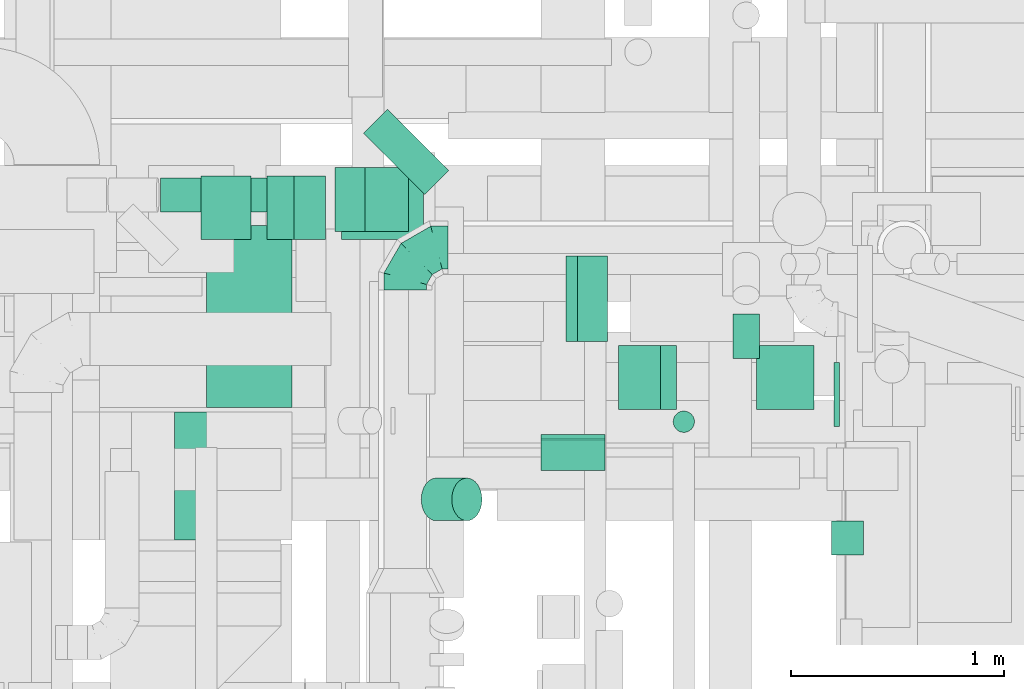
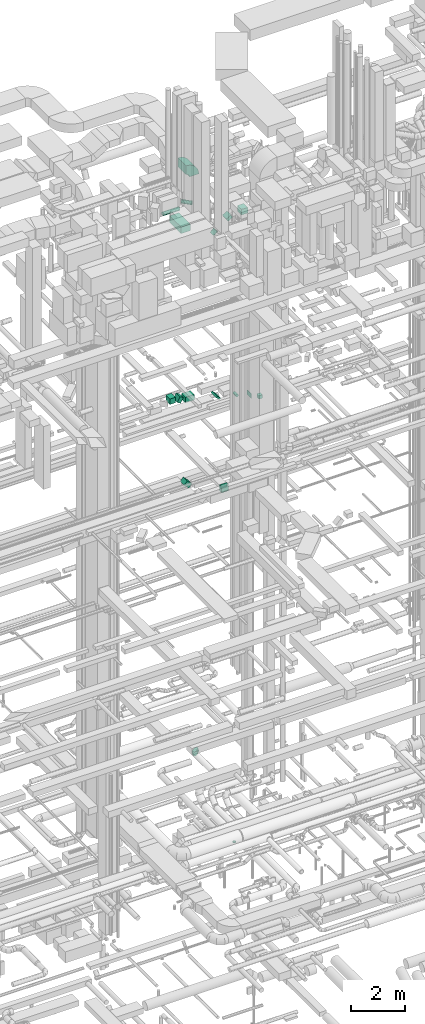
# One storey, part 202 of 337: 16 flow segments, 5 flow fittings.
"""IFC2X3 building model written with IfcOpenShell, lengths in millimetres."""

import ifcopenshell
import ifcopenshell.guid

model = None  # the IFC model being written
_history = None  # IfcOwnerHistory: only IFC2X3 demands one
_inside = {}  # id of a spatial element -> (the spatial element, [elements in it])
_under = {}  # id of a project, library or spatial element -> (it, [spatial elements below it])
_declared = {}  # id of a project -> (the project, [libraries it declares])
_typed = {}  # id of a type object -> (the type object, [elements of that type])
_made_of = {}  # id of a material, layer set ... -> (it, [elements and type objects made of it])


def new_model(schema):
    """Start an empty IFC model of exactly this schema.

    Asked for "IFC4X3", IfcOpenShell would pick the latest addendum, in which some entities
    have other attributes; the version numbers below select the first issue.
    IFC2X3 requires an IfcOwnerHistory on every rooted entity: one is made here for all.
    """
    global model, _history
    if schema == "IFC4X3":
        model = ifcopenshell.file(schema_version=(4, 3, 0, 0))
    else:
        model = ifcopenshell.file(schema=schema)
    _inside.clear()
    _under.clear()
    _declared.clear()
    _typed.clear()
    _made_of.clear()
    _history = None
    if model.schema == "IFC2X3":
        org = make("IfcOrganization", Name="unknown")
        user = make(
            "IfcPersonAndOrganization",
            ThePerson=make("IfcPerson", FamilyName="unknown"),
            TheOrganization=org,
        )
        app = make(
            "IfcApplication",
            ApplicationDeveloper=org,
            Version="unknown",
            ApplicationFullName="unknown",
            ApplicationIdentifier="unknown",
        )
        _history = make(
            "IfcOwnerHistory",
            OwningUser=user,
            OwningApplication=app,
            ChangeAction="ADDED",
            CreationDate=0,
        )
    return model


def make(cls, **values):
    """One entity of the class cls with the attributes given. An attribute that is None is left unset."""
    return model.create_entity(
        cls, **{name: value for name, value in values.items() if value is not None}
    )


def entity(cls, *values):
    """Any entity or typed value of the class cls, its attributes in the order of the schema. None: left unset."""
    e = model.create_entity(cls)
    for i, value in enumerate(values):
        if value is not None:
            e[i] = value
    return e


def rooted(cls, **values):
    """An entity with a GlobalId (a new one), such as an element, a storey or a relation."""
    return make(cls, GlobalId=ifcopenshell.guid.new(), OwnerHistory=_history, **values)


def si_unit(unit_type, name, prefix=None):
    """IfcSIUnit, for example si_unit("LENGTHUNIT", "METRE", prefix="MILLI")."""
    return make("IfcSIUnit", UnitType=unit_type, Prefix=prefix, Name=name)


def converted_unit(unit_type, name, factor, base, dimensions=None, offset=None):
    """IfcConversionBasedUnit, such as the inch: factor (a typed value) times the base unit."""
    return make(
        "IfcConversionBasedUnit"
        if offset is None
        else "IfcConversionBasedUnitWithOffset",
        ConversionOffset=offset,
        Dimensions=None
        if dimensions is None
        else entity("IfcDimensionalExponents", *dimensions),
        UnitType=unit_type,
        Name=name,
        ConversionFactor=make(
            "IfcMeasureWithUnit", ValueComponent=factor, UnitComponent=base
        ),
    )


def derived_unit(unit_type, elements):
    """IfcDerivedUnit: a product of units, each with its exponent."""
    return make(
        "IfcDerivedUnit",
        Elements=[
            make("IfcDerivedUnitElement", Unit=unit, Exponent=power)
            for unit, power in elements
        ],
        UnitType=unit_type,
    )


def assignment(units):
    """IfcUnitAssignment: the units of a project."""
    return None if units is None else make("IfcUnitAssignment", Units=units)


def point(xyz):
    """IfcCartesianPoint."""
    return None if xyz is None else make("IfcCartesianPoint", Coordinates=xyz)


def direction(xyz):
    """IfcDirection."""
    return None if xyz is None else make("IfcDirection", DirectionRatios=xyz)


def frame(location, z_axis=None, x_axis=None):
    """IfcAxis2Placement3D, a coordinate frame: its origin and axes. An axis left out is left unset."""
    return make(
        "IfcAxis2Placement3D",
        Location=point(location),
        Axis=direction(z_axis),
        RefDirection=direction(x_axis),
    )


def frame_2d(location, x_axis=None):
    """IfcAxis2Placement2D, a coordinate frame in the plane: its origin and x axis."""
    return make(
        "IfcAxis2Placement2D", Location=point(location), RefDirection=direction(x_axis)
    )


def origin():
    """The frame at (0, 0, 0) with its axes left unset."""
    return frame((0.0, 0.0, 0.0))


def origin_2d_with_axis():
    """The frame at (0, 0) in the plane with the x axis (1, 0) written out."""
    return frame_2d((0.0, 0.0), x_axis=(1.0, 0.0))


def place(relative_to, where):
    """IfcLocalPlacement: puts the frame where relative to a parent placement (None: the world)."""
    return make(
        "IfcLocalPlacement", PlacementRelTo=relative_to, RelativePlacement=where
    )


def context(
    kind, dimensions, precision=None, world=None, true_north=None, identifier=None
):
    """IfcGeometricRepresentationContext, for example the 3D "Model" context."""
    return make(
        "IfcGeometricRepresentationContext",
        ContextIdentifier=identifier,
        ContextType=kind,
        CoordinateSpaceDimension=dimensions,
        Precision=precision,
        WorldCoordinateSystem=world,
        TrueNorth=true_north,
    )


def subcontext(parent, identifier, kind, view, scale=None):
    """IfcGeometricRepresentationSubContext, for example "Body" below "Model"."""
    return make(
        "IfcGeometricRepresentationSubContext",
        ContextIdentifier=identifier,
        ContextType=kind,
        ParentContext=parent,
        TargetScale=scale,
        TargetView=view,
    )


def project(units=None, contexts=None):
    """IfcProject with its units and contexts."""
    return rooted(
        "IfcProject",
        Name="project",
        RepresentationContexts=contexts,
        UnitsInContext=assignment(units),
    )


def spatial(cls, under=None, at=None, **own):
    """A site, building, storey or space (cls), placed at a placement, below another one or the project."""
    s = rooted(cls, ObjectPlacement=at, **own)
    if under is not None:
        _under.setdefault(under.id(), (under, []))[1].append(s)
    return s


def polyline(points):
    """IfcPolyline through the points."""
    return make("IfcPolyline", Points=[point(p) for p in points])


def circle_curve(where, radius):
    """IfcCircle in the frame where."""
    return make("IfcCircle", Position=where, Radius=radius)


def parameter(value):
    """IfcParameterValue: where a trimmed curve begins or ends, as a parameter of its basis curve."""
    return model.create_entity("IfcParameterValue", value)


def trimmed(basis, trim1, trim2, sense, master):
    """IfcTrimmedCurve: the piece of a basis curve between two trims."""
    return make(
        "IfcTrimmedCurve",
        BasisCurve=basis,
        Trim1=trim1,
        Trim2=trim2,
        SenseAgreement=sense,
        MasterRepresentation=master,
    )


def segment(curve, same_sense, transition):
    """IfcCompositeCurveSegment."""
    return make(
        "IfcCompositeCurveSegment",
        Transition=transition,
        SameSense=same_sense,
        ParentCurve=curve,
    )


def composite_curve(segments, self_intersect=None):
    """IfcCompositeCurve: segments joined end to end."""
    return make("IfcCompositeCurve", Segments=segments, SelfIntersect=self_intersect)


def profile(cls, at=None, kind="AREA", **sizes):
    """A parametric profile (cls). Its sizes go by their IFC names, for example OverallWidth=200.0."""
    return make(cls, ProfileType=kind, Position=at, **sizes)


def rectangle(**sizes):
    """IfcRectangleProfileDef."""
    return profile("IfcRectangleProfileDef", **sizes)


def circle(**sizes):
    """IfcCircleProfileDef."""
    return profile("IfcCircleProfileDef", **sizes)


def outline(outer, holes=None, kind="AREA"):
    """IfcArbitraryClosedProfileDef: a profile drawn as a closed curve; with holes, ...WithVoids."""
    if holes is None:
        return make("IfcArbitraryClosedProfileDef", ProfileType=kind, OuterCurve=outer)
    return make(
        "IfcArbitraryProfileDefWithVoids",
        ProfileType=kind,
        OuterCurve=outer,
        InnerCurves=holes,
    )


def extrude(swept, where, along, depth):
    """IfcExtrudedAreaSolid: the profile swept, set in the frame where, extruded along a direction by depth."""
    return make(
        "IfcExtrudedAreaSolid",
        SweptArea=swept,
        Position=where,
        ExtrudedDirection=direction(along),
        Depth=depth,
    )


def faces_of(points, faces, orient=None, outer=None):
    """IfcFace entities. A face is a list of loops; a loop is a list of indices into points, from 0.

    orient and outer hold one flag for each loop. By default every Orientation is true, the
    first loop of a face is its IfcFaceOuterBound and the others are IfcFaceBound.
    """
    made = []
    for i, loops in enumerate(faces):
        bounds = []
        for j, loop in enumerate(loops):
            is_outer = j == 0 if outer is None else outer[i][j]
            bounds.append(
                make(
                    "IfcFaceOuterBound" if is_outer else "IfcFaceBound",
                    Bound=make("IfcPolyLoop", Polygon=[points[k] for k in loop]),
                    Orientation=True if orient is None else orient[i][j],
                )
            )
        made.append(make("IfcFace", Bounds=bounds))
    return made


def faceted_brep(points, faces, orient=None, outer=None, voids=None):
    """IfcFacetedBrep: a solid bounded by flat faces; with voids (closed shells), ...WithVoids."""
    shared = [point(p) for p in points]
    hull = make("IfcClosedShell", CfsFaces=faces_of(shared, faces, orient, outer))
    if voids is None:
        return make("IfcFacetedBrep", Outer=hull)
    return make(
        "IfcFacetedBrepWithVoids",
        Outer=hull,
        Voids=[
            make(cls, CfsFaces=faces_of(shared, fs, o, b)) for cls, fs, o, b in voids
        ],
    )


def shape(context_of_items, identifier, shape_type, items):
    """IfcShapeRepresentation: the items that make up one representation, for example the "Body"."""
    return make(
        "IfcShapeRepresentation",
        ContextOfItems=context_of_items,
        RepresentationIdentifier=identifier,
        RepresentationType=shape_type,
        Items=items,
    )


def source(mapping_origin, context_of_items, identifier, shape_type, items):
    """IfcRepresentationMap: a shape defined once, which mapped items show again and again."""
    return make(
        "IfcRepresentationMap",
        MappingOrigin=mapping_origin,
        MappedRepresentation=shape(context_of_items, identifier, shape_type, items),
    )


def transform(
    local_origin,
    x_axis=None,
    y_axis=None,
    z_axis=None,
    scale=None,
    scale2=None,
    scale3=None,
    uniform=True,
):
    """IfcCartesianTransformationOperator3D, or its non-uniform kind. x_axis, y_axis, z_axis: its Axis1, 2, 3."""
    if uniform:
        return make(
            "IfcCartesianTransformationOperator3D",
            Axis1=direction(x_axis),
            Axis2=direction(y_axis),
            LocalOrigin=point(local_origin),
            Scale=scale,
            Axis3=direction(z_axis),
        )
    return make(
        "IfcCartesianTransformationOperator3DnonUniform",
        Axis1=direction(x_axis),
        Axis2=direction(y_axis),
        LocalOrigin=point(local_origin),
        Scale=scale,
        Axis3=direction(z_axis),
        Scale2=scale2,
        Scale3=scale3,
    )


def mapped(mapping_source, mapping_target):
    """IfcMappedItem: shows the shape of a source again, moved by a transform."""
    return make(
        "IfcMappedItem", MappingSource=mapping_source, MappingTarget=mapping_target
    )


def material(Name=None, Category=None):
    """IfcMaterial."""
    return make("IfcMaterial", Name=Name, Category=Category)


def made_of(thing, what):
    """Note that an element or type object is made of a material, layer set ...; save() writes the relation."""
    if what is not None:
        _made_of.setdefault(what.id(), (what, []))[1].append(thing)
    return thing


def type_object(cls, material=None, **own):
    """A type object (cls), such as IfcWallType, which elements share."""
    return made_of(rooted(cls, **own), material)


def type_shapes(of_type, sources):
    """Give a type object the sources (RepresentationMaps) that its elements show as mapped items."""
    of_type.RepresentationMaps = sources


def element(
    cls,
    number,
    at=None,
    inside=None,
    cuts=None,
    type_object=None,
    material=None,
    context=None,
    identifier="Body",
    shape_type=None,
    held_by="IfcProductDefinitionShape",
    body=None,
    shapes=None,
    **own,
):
    """One element of the class cls, such as IfcWall. Its Tag is "e" and its number.

    at: its placement. inside: the storey or other place that contains it. cuts: it is an
    opening in that element (IfcRelVoidsElement). A single representation is given by context,
    identifier, shape_type and body (its items); several are given by shapes. held_by: the class
    of the entity that holds the representations. save() writes the other relations.
    """
    e = rooted(cls, Tag="e%d" % number, ObjectPlacement=at, **own)
    if body is not None:
        shapes = [shape(context, identifier, shape_type, body)]
    if shapes is not None:
        e.Representation = make(held_by, Representations=shapes)
    if inside is not None:
        _inside.setdefault(inside.id(), (inside, []))[1].append(e)
    if cuts is not None:
        rooted(
            "IfcRelVoidsElement", RelatingBuildingElement=cuts, RelatedOpeningElement=e
        )
    if type_object is not None:
        _typed.setdefault(type_object.id(), (type_object, []))[1].append(e)
    return made_of(e, material)


def aggregate(whole, parts):
    """IfcRelAggregates: a whole, such as a stair, and the parts it consists of."""
    return rooted("IfcRelAggregates", RelatingObject=whole, RelatedObjects=parts)


def save(model, path):
    """Write the relations noted so far, then the file.

    IfcRelAggregates (storeys below a building ...), IfcRelContainedInSpatialStructure (elements
    in a storey), IfcRelDefinesByType, IfcRelAssociatesMaterial and IfcRelDeclares: one each for
    every whole, place, type object, material and project.
    """
    for whole, parts in _under.values():
        aggregate(whole, parts)
    for where, things in _inside.values():
        rooted(
            "IfcRelContainedInSpatialStructure",
            RelatedElements=things,
            RelatingStructure=where,
        )
    for kind, things in _typed.values():
        rooted("IfcRelDefinesByType", RelatedObjects=things, RelatingType=kind)
    for what, things in _made_of.values():
        rooted("IfcRelAssociatesMaterial", RelatedObjects=things, RelatingMaterial=what)
    for by, libraries in _declared.values():
        rooted("IfcRelDeclares", RelatingContext=by, RelatedDefinitions=libraries)
    model.write(path)


model = new_model("IFC2X3")

# Units and contexts
model_context = context("Model", 3, precision=0.01, world=origin(), true_north=direction((6.12303176911189e-17, 1.0)))
body_context = subcontext(model_context, "Body", "Model", "MODEL_VIEW")
ifc_project = project(units=[si_unit("LENGTHUNIT", "METRE", prefix="MILLI"), si_unit("AREAUNIT", "SQUARE_METRE"), si_unit("VOLUMEUNIT", "CUBIC_METRE"), converted_unit("PLANEANGLEUNIT", "DEGREE", entity("IfcRatioMeasure", 0.0174532925199433), si_unit("PLANEANGLEUNIT", "RADIAN"), dimensions=[0, 0, 0, 0, 0, 0, 0]), si_unit("MASSUNIT", "GRAM", prefix="KILO"), derived_unit("MASSDENSITYUNIT", [(si_unit("MASSUNIT", "GRAM", prefix="KILO"), 1), (si_unit("LENGTHUNIT", "METRE"), -3)]), derived_unit("MOMENTOFINERTIAUNIT", [(si_unit("LENGTHUNIT", "METRE"), 4)]), si_unit("TIMEUNIT", "SECOND"), si_unit("FREQUENCYUNIT", "HERTZ"), si_unit("THERMODYNAMICTEMPERATUREUNIT", "DEGREE_CELSIUS"), derived_unit("THERMALTRANSMITTANCEUNIT", [(si_unit("MASSUNIT", "GRAM", prefix="KILO"), 1), (si_unit("THERMODYNAMICTEMPERATUREUNIT", "KELVIN"), -1), (si_unit("TIMEUNIT", "SECOND"), -3)]), derived_unit("VOLUMETRICFLOWRATEUNIT", [(si_unit("LENGTHUNIT", "METRE"), 3), (si_unit("TIMEUNIT", "SECOND"), -1)]), derived_unit("MASSFLOWRATEUNIT", [(si_unit("MASSUNIT", "GRAM", prefix="KILO"), 1), (si_unit("TIMEUNIT", "SECOND"), -1)]), derived_unit("ROTATIONALFREQUENCYUNIT", [(si_unit("TIMEUNIT", "SECOND"), -1)]), si_unit("ELECTRICCURRENTUNIT", "AMPERE"), si_unit("ELECTRICVOLTAGEUNIT", "VOLT"), si_unit("POWERUNIT", "WATT"), si_unit("FORCEUNIT", "NEWTON", prefix="KILO"), si_unit("ILLUMINANCEUNIT", "LUX"), si_unit("LUMINOUSFLUXUNIT", "LUMEN"), si_unit("LUMINOUSINTENSITYUNIT", "CANDELA"), derived_unit("USERDEFINED", [(si_unit("MASSUNIT", "GRAM", prefix="KILO"), -1), (si_unit("LENGTHUNIT", "METRE"), -2), (si_unit("TIMEUNIT", "SECOND"), 3), (si_unit("LUMINOUSFLUXUNIT", "LUMEN"), 1)]), derived_unit("LINEARVELOCITYUNIT", [(si_unit("LENGTHUNIT", "METRE"), 1), (si_unit("TIMEUNIT", "SECOND"), -1)]), si_unit("PRESSUREUNIT", "PASCAL"), derived_unit("USERDEFINED", [(si_unit("LENGTHUNIT", "METRE"), -2), (si_unit("MASSUNIT", "GRAM", prefix="KILO"), 1), (si_unit("TIMEUNIT", "SECOND"), -2)]), derived_unit("LINEARFORCEUNIT", [(si_unit("MASSUNIT", "GRAM", prefix="KILO"), 1), (si_unit("LENGTHUNIT", "METRE"), 1), (si_unit("TIMEUNIT", "SECOND"), -2), (si_unit("LENGTHUNIT", "METRE"), -1)]), derived_unit("PLANARFORCEUNIT", [(si_unit("MASSUNIT", "GRAM", prefix="KILO"), 1), (si_unit("LENGTHUNIT", "METRE"), 1), (si_unit("TIMEUNIT", "SECOND"), -2), (si_unit("LENGTHUNIT", "METRE"), -2)])], contexts=[model_context])

# Site, building, storey
site_placement = place(None, origin())
site = spatial("IfcSite", under=ifc_project, at=site_placement, CompositionType="ELEMENT")
building_placement = place(site_placement, origin())
building = spatial("IfcBuilding", under=site, at=building_placement, CompositionType="ELEMENT")
storey_placement = place(building_placement, origin())
storey = spatial("IfcBuildingStorey", under=building, at=storey_placement, CompositionType="ELEMENT", Elevation=0.0)

# Flow segments
duct_segment_type_1 = type_object("IfcDuctSegmentType", PredefinedType="NOTDEFINED")
flow_segment_1_placement = place(storey_placement, frame((51802.55, 14775.52, 18952.51)))
element("IfcFlowSegment", 1, at=flow_segment_1_placement, inside=storey, type_object=duct_segment_type_1, context=body_context, shape_type="SweptSolid", body=[
    extrude(rectangle(XDim=200.00000000001, YDim=75.735931288074, at=frame_2d((0.0, 0.0), x_axis=(0.0, 1.0))), frame((97.49, 0.0, 97.49), z_axis=(0.0, 1.0, 0.0), x_axis=(-0.707106781186562, 0.0, -0.707106781186533)), (0.0, 0.0, 1.0), 400.0),
])
flow_segment_2_placement = place(storey_placement, frame((50748.79, 15251.67, 18940.81)))
element("IfcFlowSegment", 2, at=flow_segment_2_placement, inside=storey, type_object=duct_segment_type_1, context=body_context, shape_type="SweptSolid", body=[
    extrude(rectangle(XDim=384.354268539352, YDim=299.999999999999, at=origin_2d_with_axis()), frame((192.18, 150.0, 0.0), z_axis=(0.0, 0.0, 1.0), x_axis=(-1.0, 0.0, 0.0)), (0.0, 0.0, 1.0), 249.999999999999),
])
flow_segment_3_placement = place(storey_placement, frame((50091.2, 15251.67, 19100.02)))
element("IfcFlowSegment", 3, at=flow_segment_3_placement, inside=storey, type_object=duct_segment_type_1, context=body_context, shape_type="SweptSolid", body=[
    extrude(rectangle(XDim=234.471828348611, YDim=300.000000000001, at=origin_2d_with_axis()), frame((117.24, 150.0, 0.0), z_axis=(0.0, 0.0, 1.0), x_axis=(-1.0, 0.0, 0.0)), (0.0, 0.0, 1.0), 249.999999999999),
])
flow_segment_4_placement = place(storey_placement, frame((50400.67, 15251.67, 18994.4)))
element("IfcFlowSegment", 4, at=flow_segment_4_placement, inside=storey, type_object=duct_segment_type_1, context=body_context, shape_type="SweptSolid", body=[
    extrude(rectangle(XDim=250.000000000002, YDim=171.03352482049, at=frame_2d((0.0, 0.0), x_axis=(0.0, 1.0))), frame((136.56, 0.0, 151.01), z_axis=(0.0, 1.0, 0.0), x_axis=(-0.866025035284183, 0.0, 0.500000638260622)), (0.0, 0.0, 1.0), 300.000000000001),
])
flow_segment_5_placement = place(storey_placement, frame((53046.72, 13773.66, 19200.0)))
element("IfcFlowSegment", 5, at=flow_segment_5_placement, inside=storey, type_object=duct_segment_type_1, context=body_context, shape_type="SweptSolid", body=[
    extrude(rectangle(XDim=159.073051533944, YDim=150.000000000001, at=origin_2d_with_axis()), frame((75.0, 79.54, 0.0), z_axis=(0.0, 0.0, 1.0), x_axis=(0.0, -1.0, 0.0)), (0.0, 0.0, 1.0), 150.000000000001),
])
flow_segment_6_placement = place(storey_placement, frame((53059.03, 14375.32, 18875.0)))
element("IfcFlowSegment", 6, at=flow_segment_6_placement, inside=storey, type_object=duct_segment_type_1, context=body_context, shape_type="SweptSolid", body=[
    extrude(rectangle(XDim=26.4466094067052, YDim=300.000000000001, at=origin_2d_with_axis()), frame((13.22, 150.0, 0.0)), (0.0, 0.0, 1.0), 199.999999999998),
])
flow_segment_7_placement = place(storey_placement, frame((50718.26, 15290.0, 15002.51)))
element("IfcFlowSegment", 7, at=flow_segment_7_placement, inside=storey, type_object=duct_segment_type_1, context=body_context, shape_type="SweptSolid", body=[
    extrude(rectangle(XDim=287.867965644034, YDim=199.999999999996, at=origin_2d_with_axis()), frame((172.49, 0.0, 172.49), z_axis=(0.0, 1.0, 0.0), x_axis=(0.707106781186502, 0.0, -0.707106781186593)), (0.0, 0.0, 1.0), 300.000000000001),
])
flow_segment_8_placement = place(storey_placement, frame((50116.44, 14464.03, 27300.0)))
element("IfcFlowSegment", 8, at=flow_segment_8_placement, inside=storey, type_object=duct_segment_type_1, context=body_context, shape_type="SweptSolid", body=[
    extrude(rectangle(XDim=855.342919999985, YDim=400.000000000004, at=origin_2d_with_axis()), frame((200.0, 427.67, 0.0), z_axis=(0.0, 0.0, 1.0), x_axis=(0.0, 1.0, 0.0)), (0.0, 0.0, 1.0), 300.000000000001),
])
flow_segment_9_placement = place(storey_placement, frame((52695.91, 14456.21, 27250.0)))
element("IfcFlowSegment", 9, at=flow_segment_9_placement, inside=storey, type_object=duct_segment_type_1, context=body_context, shape_type="SweptSolid", body=[
    extrude(rectangle(XDim=269.911341373758, YDim=299.999999999999, at=origin_2d_with_axis()), frame((134.96, 150.0, 0.0), z_axis=(0.0, 0.0, 1.0), x_axis=(-1.0, 0.0, 0.0)), (0.0, 0.0, 1.0), 250.000000000004),
])
flow_segment_10_placement = place(storey_placement, frame((52047.22, 14456.21, 27165.19)))
element("IfcFlowSegment", 10, at=flow_segment_10_placement, inside=storey, type_object=duct_segment_type_1, context=body_context, shape_type="SweptSolid", body=[
    extrude(rectangle(XDim=150.000000000004, YDim=229.422875147556, at=frame_2d((0.0, 0.0), x_axis=(0.0, 1.0))), frame((136.84, 0.0, 122.31), z_axis=(0.0, 1.0, 0.0), x_axis=(-0.866025410712627, 0.0, -0.499999988000025)), (0.0, 0.0, 1.0), 300.000000000001),
])
flow_segment_11_placement = place(storey_placement, frame((51683.97, 14168.91, 15220.0)))
element("IfcFlowSegment", 11, at=flow_segment_11_placement, inside=storey, type_object=duct_segment_type_1, context=body_context, shape_type="SweptSolid", body=[
    extrude(rectangle(XDim=150.000000000001, YDim=300.000000000001, at=origin_2d_with_axis()), frame((150.0, 75.0, 0.0), z_axis=(0.0, 0.0, 1.0), x_axis=(0.0, -1.0, 0.0)), (0.0, 0.0, 1.0), 235.000000000014),
])
duct_segment_type_2 = type_object("IfcDuctSegmentType", PredefinedType="NOTDEFINED")
flow_segment_12_placement = place(storey_placement, frame((52582.47, 14695.32, 18885.9)))
element("IfcFlowSegment", 12, at=flow_segment_12_placement, inside=storey, type_object=duct_segment_type_2, context=body_context, shape_type="SweptSolid", body=[
    extrude(circle(Radius=62.5, at=origin_2d_with_axis()), frame((64.1, 0.0, 64.1), z_axis=(0.0, 1.0, 0.0), x_axis=(1.0, 0.0, 0.0)), (0.0, 0.0, 1.0), 208.223304703391),
])
flow_segment_13_placement = place(storey_placement, frame((51121.8, 13932.68, 27100.98)))
element("IfcFlowSegment", 13, at=flow_segment_13_placement, inside=storey, type_object=duct_segment_type_2, context=body_context, shape_type="SweptSolid", body=[
    extrude(circle(Radius=100.0, at=origin_2d_with_axis()), frame((72.31, 101.6, 72.31), z_axis=(0.707106781186548, 0.0, 0.707106781186548), x_axis=(0.0, 1.0, 0.0)), (0.0, 0.0, 1.0), 202.424674324503),
])
flow_segment_14_placement = place(storey_placement, frame((49901.21, 15380.23, 27588.4)))
element("IfcFlowSegment", 14, at=flow_segment_14_placement, inside=storey, type_object=duct_segment_type_2, context=body_context, shape_type="SweptSolid", body=[
    extrude(circle(Radius=80.0, at=origin_2d_with_axis()), frame((0.0, 81.6, 81.6), z_axis=(1.0, 0.0, 0.0), x_axis=(0.0, -1.0, 0.0)), (0.0, 0.0, 1.0), 695.413542972159),
])
flow_segment_15_placement = place(storey_placement, frame((50849.76, 15461.1, 27598.4)))
element("IfcFlowSegment", 15, at=flow_segment_15_placement, inside=storey, type_object=duct_segment_type_2, context=body_context, shape_type="SweptSolid", body=[
    extrude(circle(Radius=80.0, at=origin_2d_with_axis()), frame((58.16, 346.28, 81.6), z_axis=(0.707106781186542, -0.707106781186553, 0.0), x_axis=(0.707106781186553, 0.707106781186542, 0.0)), (0.0, 0.0, 1.0), 407.451660040605),
])
flow_segment_16_placement = place(storey_placement, frame((52303.03, 14346.8, -980.0)))
element("IfcFlowSegment", 16, at=flow_segment_16_placement, inside=storey, type_object=duct_segment_type_2, context=body_context, shape_type="SweptSolid", body=[
    extrude(circle(Radius=50.0, at=origin_2d_with_axis()), frame((51.6, 51.6, 0.0), z_axis=(0.0, 0.0, 1.0), x_axis=(-1.0, 0.0, 0.0)), (0.0, 0.0, 1.0), 29.9999750000201),
])

# Flow fittings
ifc_material = material()
duct_fitting_type_1 = type_object("IfcDuctFittingType", PredefinedType="NOTDEFINED", material=ifc_material)
shared_shape_1 = source(origin(), body_context, "Body", "SweptSolid", [
    extrude(rectangle(XDim=26.0960000000005, YDim=300.0, at=origin_2d_with_axis()), frame((6.95, 0.0, -75.0)), (0.0, 0.0, 1.0), 150.0),
])
type_shapes(duct_fitting_type_1, [shared_shape_1])
flow_fitting_1_placement = place(storey_placement, frame((51833.97, 14243.91, 15200.0), z_axis=(0.0, -1.0, 0.0), x_axis=(0.0, 0.0, 1.0)))
element("IfcFlowFitting", 17, at=flow_fitting_1_placement, inside=storey, type_object=duct_fitting_type_1, material=ifc_material, context=body_context, shape_type="MappedRepresentation", body=[
    mapped(shared_shape_1, transform((0.0, 0.0, 0.0), scale=1.0)),
])
duct_fitting_type_2 = type_object("IfcDuctFittingType", PredefinedType="NOTDEFINED", material=ifc_material)
shared_shape_2 = source(origin(), body_context, "Body", "SweptSolid", [
    extrude(rectangle(XDim=26.0960000000132, YDim=150.0, at=origin_2d_with_axis()), frame((6.95, 0.0, -150.0)), (0.0, 0.0, 1.0), 300.0),
])
type_shapes(duct_fitting_type_2, [shared_shape_2])
flow_fitting_2_placement = place(storey_placement, frame((51833.97, 14318.91, 15375.0), z_axis=(1.0, 0.0, 0.0), x_axis=(0.0, 1.0, 0.0)))
element("IfcFlowFitting", 18, at=flow_fitting_2_placement, inside=storey, type_object=duct_fitting_type_2, material=ifc_material, context=body_context, shape_type="MappedRepresentation", body=[
    mapped(shared_shape_2, transform((0.0, 0.0, 0.0), scale=1.0)),
])
duct_fitting_type_3 = type_object("IfcDuctFittingType", PredefinedType="NOTDEFINED", material=ifc_material)
shared_shape_3 = source(origin(), body_context, "Body", "SweptSolid", [
    extrude(rectangle(XDim=24.9999999999999, YDim=300.0, at=origin_2d_with_axis()), frame((12.5, 0.0, -75.0)), (0.0, 0.0, 1.0), 150.0),
])
type_shapes(duct_fitting_type_3, [shared_shape_3])
flow_fitting_3_placement = place(storey_placement, frame((51833.97, 14243.91, 15455.0), z_axis=(0.0, -1.0, 0.0), x_axis=(0.0, 0.0, 1.0)))
element("IfcFlowFitting", 19, at=flow_fitting_3_placement, inside=storey, type_object=duct_fitting_type_3, material=ifc_material, context=body_context, shape_type="MappedRepresentation", body=[
    mapped(shared_shape_3, transform((0.0, 0.0, 0.0), scale=1.0)),
])
duct_fitting_type_4 = type_object("IfcDuctFittingType", PredefinedType="NOTDEFINED", material=ifc_material)
shared_shape_4 = source(origin(), body_context, "Body", "Brep", [
    faceted_brep([(-200.0, 0.0, -100.0), (-200.0, -25.88, -96.59), (-200.0, -50.0, -86.6), (-200.0, -70.71, -70.71), (-200.0, -86.6, -50.0), (-200.0, -96.59, -25.88), (-200.0, -100.0, 0.0), (-200.0, -96.59, 25.88), (-200.0, -86.6, 50.0), (-200.0, -70.71, 70.71), (-200.0, -50.0, 86.6), (-200.0, -25.88, 96.59), (-200.0, 0.0, 100.0), (-200.0, 25.88, 96.59), (-200.0, 50.0, 86.6), (-200.0, 70.71, 70.71), (-200.0, 86.6, 50.0), (-200.0, 96.59, 25.88), (-200.0, 100.0, 0.0), (-200.0, 96.59, -25.88), (-200.0, 86.6, -50.0), (-200.0, 70.71, -70.71), (-200.0, 50.0, -86.6), (-200.0, 25.88, -96.59), (-153.35, 25.88, 96.59), (-159.81, 50.0, 86.6), (-146.41, 0.0, 100.0), (-165.36, 70.71, 70.71), (-172.29, 96.59, 25.88), (-173.21, 100.0, 0.0), (-169.62, 86.6, 50.0), (-169.62, 86.6, -50.0), (-165.36, 70.71, -70.71), (-172.29, 96.59, -25.88), (-153.35, 25.88, -96.59), (-146.41, 0.0, -100.0), (-159.81, 50.0, -86.6), (-139.48, -25.88, -96.59), (-133.01, -50.0, -86.6), (-127.46, -70.71, -70.71), (-123.21, -86.6, -50.0), (-120.53, -96.59, -25.88), (-119.62, -100.0, 0.0), (-120.53, -96.59, 25.88), (-123.21, -86.6, 50.0), (-127.46, -70.71, 70.71), (-133.01, -50.0, 86.6), (-139.48, -25.88, 96.59), (-72.54, 72.54, 96.59), (-90.19, 90.19, 86.6), (-53.59, 53.59, 100.0), (-105.35, 105.35, 70.71), (-116.99, 116.99, 50.0), (-124.3, 124.3, 25.88), (-126.79, 126.79, 0.0), (-124.3, 124.3, -25.88), (-116.99, 116.99, -50.0), (-105.35, 105.35, -70.71), (-72.54, 72.54, -96.59), (-53.59, 53.59, -100.0), (-90.19, 90.19, -86.6), (-34.64, 34.64, -96.59), (-16.99, 16.99, -86.6), (-1.83, 1.83, -70.71), (9.81, -9.81, -50.0), (17.12, -17.12, -25.88), (19.62, -19.62, 0.0), (17.12, -17.12, 25.88), (9.81, -9.81, 50.0), (-1.83, 1.83, 70.71), (-16.99, 16.99, 86.6), (-34.64, 34.64, 96.59), (-25.88, 153.35, 96.59), (-50.0, 159.81, 86.6), (0.0, 146.41, 100.0), (-70.71, 165.36, 70.71), (-86.6, 169.62, 50.0), (-96.59, 172.29, 25.88), (-100.0, 173.21, 0.0), (-96.59, 172.29, -25.88), (-86.6, 169.62, -50.0), (-70.71, 165.36, -70.71), (-25.88, 153.35, -96.59), (0.0, 146.41, -100.0), (-50.0, 159.81, -86.6), (25.88, 139.48, -96.59), (50.0, 133.01, -86.6), (70.71, 127.46, -70.71), (86.6, 123.21, -50.0), (96.59, 120.53, -25.88), (100.0, 119.62, 0.0), (96.59, 120.53, 25.88), (86.6, 123.21, 50.0), (70.71, 127.46, 70.71), (50.0, 133.01, 86.6), (25.88, 139.48, 96.59), (-25.88, 200.0, -96.59), (-50.0, 200.0, -86.6), (-70.71, 200.0, -70.71), (-86.6, 200.0, -50.0), (-96.59, 200.0, -25.88), (-100.0, 200.0, 0.0), (-96.59, 200.0, 25.88), (-86.6, 200.0, 50.0), (-70.71, 200.0, 70.71), (-50.0, 200.0, 86.6), (-25.88, 200.0, 96.59), (0.0, 200.0, 100.0), (25.88, 200.0, 96.59), (50.0, 200.0, 86.6), (70.71, 200.0, 70.71), (86.6, 200.0, 50.0), (96.59, 200.0, 25.88), (100.0, 200.0, 0.0), (96.59, 200.0, -25.88), (86.6, 200.0, -50.0), (70.71, 200.0, -70.71), (50.0, 200.0, -86.6), (25.88, 200.0, -96.59), (0.0, 200.0, -100.0)], [[[0, 1, 2, 3, 4, 5, 6, 7, 8, 9, 10, 11, 12, 13, 14, 15, 16, 17, 18, 19, 20, 21, 22, 23]], [[24, 25, 14, 13]], [[26, 24, 13, 12]], [[14, 25, 27, 15]], [[28, 29, 18, 17]], [[30, 28, 17, 16]], [[15, 27, 30, 16]], [[20, 31, 32, 21]], [[33, 31, 20, 19]], [[18, 29, 33, 19]], [[34, 35, 0, 23]], [[36, 34, 23, 22]], [[32, 36, 22, 21]], [[1, 0, 35, 37]], [[2, 1, 37, 38]], [[38, 39, 3, 2]], [[5, 4, 40, 41]], [[6, 5, 41, 42]], [[39, 40, 4, 3]], [[6, 42, 43, 7]], [[7, 43, 44, 8]], [[8, 44, 45, 9]], [[9, 45, 46, 10]], [[10, 46, 47, 11]], [[26, 12, 11, 47]], [[48, 49, 25, 24]], [[50, 48, 24, 26]], [[27, 25, 49, 51]], [[52, 53, 28, 30]], [[51, 52, 30, 27]], [[29, 28, 53, 54]], [[55, 56, 31, 33]], [[54, 55, 33, 29]], [[32, 31, 56, 57]], [[58, 59, 35, 34]], [[60, 58, 34, 36]], [[57, 60, 36, 32]], [[37, 35, 59, 61]], [[38, 37, 61, 62]], [[39, 38, 62, 63]], [[41, 40, 64, 65]], [[42, 41, 65, 66]], [[63, 64, 40, 39]], [[43, 42, 66, 67]], [[44, 43, 67, 68]], [[68, 69, 45, 44]], [[46, 45, 69, 70]], [[47, 46, 70, 71]], [[26, 47, 71, 50]], [[72, 73, 49, 48]], [[74, 72, 48, 50]], [[51, 49, 73, 75]], [[76, 77, 53, 52]], [[75, 76, 52, 51]], [[54, 53, 77, 78]], [[79, 80, 56, 55]], [[78, 79, 55, 54]], [[57, 56, 80, 81]], [[82, 83, 59, 58]], [[84, 82, 58, 60]], [[81, 84, 60, 57]], [[61, 59, 83, 85]], [[62, 61, 85, 86]], [[63, 62, 86, 87]], [[65, 64, 88, 89]], [[66, 65, 89, 90]], [[87, 88, 64, 63]], [[67, 66, 90, 91]], [[68, 67, 91, 92]], [[92, 93, 69, 68]], [[70, 69, 93, 94]], [[71, 70, 94, 95]], [[50, 71, 95, 74]], [[96, 97, 98, 99, 100, 101, 102, 103, 104, 105, 106, 107, 108, 109, 110, 111, 112, 113, 114, 115, 116, 117, 118, 119]], [[72, 74, 107, 106]], [[73, 72, 106, 105]], [[75, 73, 105, 104]], [[102, 101, 78, 77]], [[103, 102, 77, 76]], [[75, 104, 103, 76]], [[78, 101, 100, 79]], [[79, 100, 99, 80]], [[80, 99, 98, 81]], [[84, 97, 96, 82]], [[82, 96, 119, 83]], [[84, 81, 98, 97]], [[118, 117, 86, 85]], [[119, 118, 85, 83]], [[116, 87, 86, 117]], [[88, 115, 114, 89]], [[89, 114, 113, 90]], [[115, 88, 87, 116]], [[91, 90, 113, 112]], [[92, 91, 112, 111]], [[111, 110, 93, 92]], [[95, 94, 109, 108]], [[74, 95, 108, 107]], [[110, 109, 94, 93]]]),
])
type_shapes(duct_fitting_type_4, [shared_shape_4])
flow_fitting_4_placement = place(storey_placement, frame((51048.26, 15215.07, 3099.98), z_axis=(0.0, 0.0, 1.0), x_axis=(-1.0, 0.0, 0.0)))
element("IfcFlowFitting", 20, at=flow_fitting_4_placement, inside=storey, type_object=duct_fitting_type_4, material=ifc_material, context=body_context, shape_type="MappedRepresentation", body=[
    mapped(shared_shape_4, transform((0.0, 0.0, 0.0), scale=1.0)),
])
duct_fitting_type_5 = type_object("IfcDuctFittingType", PredefinedType="NOTDEFINED", material=ifc_material)
shared_shape_5 = source(origin(), body_context, "Body", "SweptSolid", [
    extrude(outline(composite_curve([segment(polyline([(-375.0, -175.0), (25.0, -175.0)]), True, "CONTINUOUS"), segment(trimmed(circle_curve(frame_2d((175.0, -175.0), x_axis=(0.0, 1.0)), 150.0), [parameter(0.0)], [parameter(90.0000000000001)], True, "PARAMETER"), False, "CONTINUOUS"), segment(polyline([(175.0, -25.0), (175.0, 375.0)]), True, "CONTINUOUS"), segment(trimmed(circle_curve(frame_2d((175.0, -175.0), x_axis=(0.0, 1.0)), 550.0), [parameter(0.0)], [parameter(90.0)], True, "PARAMETER"), True, "CONTINUOUS")], self_intersect=False)), frame((-175.0, 175.0, -300.0), z_axis=(0.0, 0.0, 1.0), x_axis=(-1.0, 0.0, 0.0)), (0.0, 0.0, 1.0), 600.0),
])
type_shapes(duct_fitting_type_5, [shared_shape_5])
flow_fitting_5_placement = place(storey_placement, frame((50316.44, 14144.03, 30600.0), z_axis=(0.0, 1.0, 0.0), x_axis=(1.0, 0.0, 0.0)))
element("IfcFlowFitting", 21, at=flow_fitting_5_placement, inside=storey, type_object=duct_fitting_type_5, material=ifc_material, context=body_context, shape_type="MappedRepresentation", body=[
    mapped(shared_shape_5, transform((0.0, 0.0, 0.0), scale=1.0)),
])

save(model, "model.ifc")
